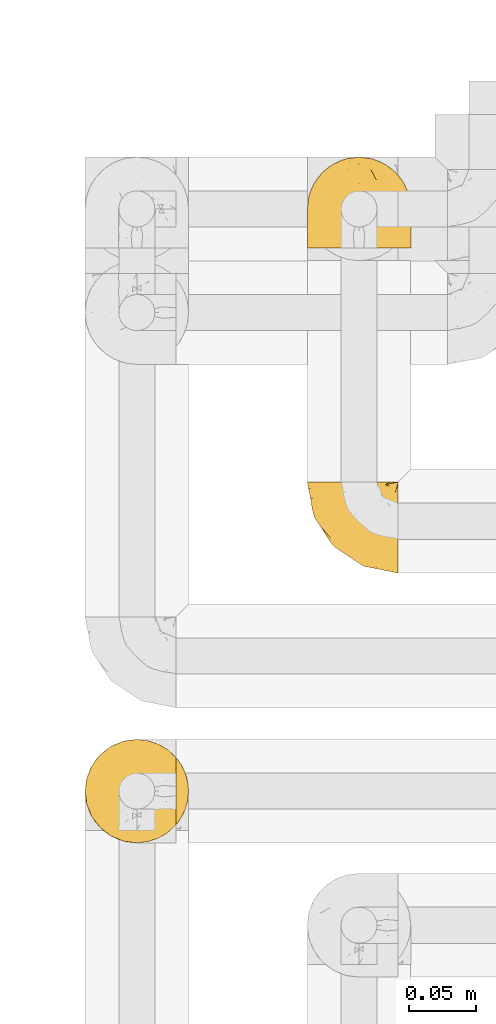
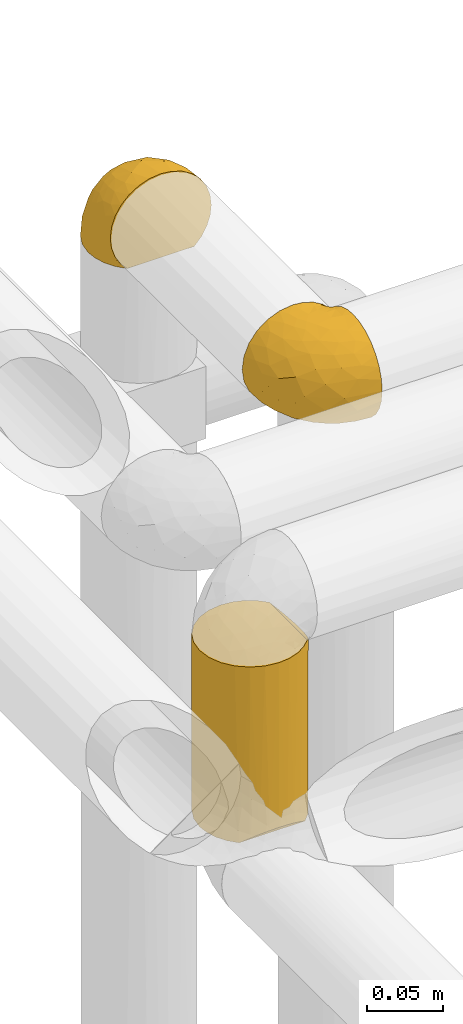
# One storey, part 294 of 827: 3 coverings.
"""IFC2X3 building model written with IfcOpenShell, lengths in millimetres."""

from ifc_helpers import new_model, entity, si_unit, converted_unit, derived_unit, direction, frame, origin, place, context, subcontext, project, spatial, faceted_brep, element, save


model = new_model("IFC2X3")

# Units and contexts
model_context = context("Model", 3, precision=0.01, world=origin(), true_north=direction((6.12303176911189e-17, 1.0)))
body_context = subcontext(model_context, "Body", "Model", "MODEL_VIEW")
ifc_project = project(units=[si_unit("LENGTHUNIT", "METRE", prefix="MILLI"), si_unit("AREAUNIT", "SQUARE_METRE"), si_unit("VOLUMEUNIT", "CUBIC_METRE"), converted_unit("PLANEANGLEUNIT", "DEGREE", entity("IfcRatioMeasure", 0.0174532925199433), si_unit("PLANEANGLEUNIT", "RADIAN"), dimensions=[0, 0, 0, 0, 0, 0, 0]), si_unit("MASSUNIT", "GRAM", prefix="KILO"), derived_unit("MASSDENSITYUNIT", [(si_unit("MASSUNIT", "GRAM", prefix="KILO"), 1), (si_unit("LENGTHUNIT", "METRE"), -3)]), derived_unit("MOMENTOFINERTIAUNIT", [(si_unit("LENGTHUNIT", "METRE"), 4)]), si_unit("TIMEUNIT", "SECOND"), si_unit("FREQUENCYUNIT", "HERTZ"), si_unit("THERMODYNAMICTEMPERATUREUNIT", "DEGREE_CELSIUS"), derived_unit("THERMALTRANSMITTANCEUNIT", [(si_unit("MASSUNIT", "GRAM", prefix="KILO"), 1), (si_unit("THERMODYNAMICTEMPERATUREUNIT", "KELVIN"), -1), (si_unit("TIMEUNIT", "SECOND"), -3)]), derived_unit("VOLUMETRICFLOWRATEUNIT", [(si_unit("LENGTHUNIT", "METRE"), 3), (si_unit("TIMEUNIT", "SECOND"), -1)]), derived_unit("MASSFLOWRATEUNIT", [(si_unit("MASSUNIT", "GRAM", prefix="KILO"), 1), (si_unit("TIMEUNIT", "SECOND"), -1)]), derived_unit("ROTATIONALFREQUENCYUNIT", [(si_unit("TIMEUNIT", "SECOND"), -1)]), si_unit("ELECTRICCURRENTUNIT", "AMPERE"), si_unit("ELECTRICVOLTAGEUNIT", "VOLT"), si_unit("POWERUNIT", "WATT"), si_unit("FORCEUNIT", "NEWTON", prefix="KILO"), si_unit("ILLUMINANCEUNIT", "LUX"), si_unit("LUMINOUSFLUXUNIT", "LUMEN"), si_unit("LUMINOUSINTENSITYUNIT", "CANDELA"), derived_unit("USERDEFINED", [(si_unit("MASSUNIT", "GRAM", prefix="KILO"), -1), (si_unit("LENGTHUNIT", "METRE"), -2), (si_unit("TIMEUNIT", "SECOND"), 3), (si_unit("LUMINOUSFLUXUNIT", "LUMEN"), 1)]), derived_unit("LINEARVELOCITYUNIT", [(si_unit("LENGTHUNIT", "METRE"), 1), (si_unit("TIMEUNIT", "SECOND"), -1)]), si_unit("PRESSUREUNIT", "PASCAL"), derived_unit("USERDEFINED", [(si_unit("LENGTHUNIT", "METRE"), -2), (si_unit("MASSUNIT", "GRAM", prefix="KILO"), 1), (si_unit("TIMEUNIT", "SECOND"), -2)]), derived_unit("LINEARFORCEUNIT", [(si_unit("MASSUNIT", "GRAM", prefix="KILO"), 1), (si_unit("LENGTHUNIT", "METRE"), 1), (si_unit("TIMEUNIT", "SECOND"), -2), (si_unit("LENGTHUNIT", "METRE"), -1)]), derived_unit("PLANARFORCEUNIT", [(si_unit("MASSUNIT", "GRAM", prefix="KILO"), 1), (si_unit("LENGTHUNIT", "METRE"), 1), (si_unit("TIMEUNIT", "SECOND"), -2), (si_unit("LENGTHUNIT", "METRE"), -2)])], contexts=[model_context])

# Site, building, storey
site_placement = place(None, origin())
site = spatial("IfcSite", under=ifc_project, at=site_placement, CompositionType="ELEMENT")
building_placement = place(site_placement, origin())
building = spatial("IfcBuilding", under=site, at=building_placement, CompositionType="ELEMENT")
storey_placement = place(building_placement, frame((0.0, 0.0, 28200.0)))
storey = spatial("IfcBuildingStorey", under=building, at=storey_placement, Name="08", CompositionType="ELEMENT", Elevation=28200.0)

# Coverings
covering_1_placement = place(storey_placement, frame((34952.84, 15549.99, 2959.95)))
element("IfcCovering", 1, at=covering_1_placement, inside=storey, Name=":ADSK_", ObjectType=":ADSK_", PredefinedType="INSULATION", context=body_context, shape_type="Brep", body=[
    faceted_brep([(69.15, 23.36, 74.68), (69.15, 16.07, 70.1), (69.15, 9.98, 64.01), (69.15, 5.4, 56.72), (69.15, 2.56, 48.6), (69.15, 1.6, 40.05), (69.15, 2.56, 31.49), (69.15, 5.41, 23.36), (69.15, 9.99, 16.07), (69.15, 16.08, 9.98), (69.15, 23.37, 5.4), (69.15, 31.49, 2.56), (69.15, 40.05, 1.6), (69.15, 48.15, 2.46), (69.15, 55.88, 5.01), (69.15, 62.9, 9.13), (69.15, 68.89, 14.62), (69.15, 68.89, 16.82), (69.15, 68.89, 18.56), (69.15, 68.89, 20.52), (69.15, 68.89, 22.49), (69.15, 68.89, 24.46), (69.15, 68.89, 26.42), (69.15, 68.89, 28.39), (69.15, 68.89, 30.36), (69.15, 68.89, 32.55), (69.15, 68.89, 34.75), (69.15, 68.89, 36.94), (69.15, 68.89, 39.13), (69.15, 68.89, 41.33), (69.15, 68.89, 43.52), (69.15, 68.89, 45.72), (69.15, 68.89, 47.91), (69.15, 68.89, 50.11), (69.15, 68.89, 52.3), (69.15, 68.89, 54.49), (69.15, 68.89, 56.69), (69.15, 68.89, 58.88), (69.15, 68.89, 61.08), (69.15, 68.89, 63.27), (69.15, 68.89, 65.47), (69.15, 62.89, 70.97), (69.15, 55.86, 75.09), (69.15, 48.13, 77.64), (69.15, 40.05, 78.5), (69.15, 31.49, 77.53), (68.89, 69.15, 14.62), (62.89, 69.15, 9.12), (55.87, 69.15, 5.0), (48.14, 69.15, 2.46), (40.05, 69.15, 1.6), (30.09, 69.15, 2.91), (20.82, 69.15, 6.75), (12.86, 69.15, 12.86), (6.75, 69.15, 20.82), (2.91, 69.15, 30.09), (1.6, 69.15, 40.05), (2.91, 69.15, 50.0), (6.75, 69.15, 59.27), (12.86, 69.15, 67.23), (20.82, 69.15, 73.34), (30.09, 69.15, 77.19), (40.05, 69.15, 78.5), (48.14, 69.15, 77.63), (55.87, 69.15, 75.09), (62.89, 69.15, 70.97), (68.89, 69.15, 65.47), (68.89, 69.15, 63.27), (68.89, 69.15, 62.29), (68.89, 69.15, 60.7), (68.89, 69.15, 59.11), (68.89, 69.15, 57.52), (68.89, 69.15, 55.93), (68.89, 69.15, 54.34), (68.89, 69.15, 52.76), (68.89, 69.15, 51.17), (68.89, 69.15, 49.58), (68.89, 69.15, 47.99), (68.89, 69.15, 46.4), (68.89, 69.15, 44.81), (68.89, 69.15, 43.22), (68.89, 69.15, 41.63), (68.89, 69.15, 40.05), (68.89, 69.15, 38.46), (68.89, 69.15, 36.87), (68.89, 69.15, 35.28), (68.89, 69.15, 33.69), (68.89, 69.15, 32.1), (68.89, 69.15, 30.51), (68.89, 69.15, 28.92), (68.89, 69.15, 27.33), (68.89, 69.15, 25.37), (68.89, 69.15, 23.4), (68.89, 69.15, 21.21), (68.89, 69.15, 19.01), (68.89, 69.15, 16.82), (68.97, 68.96, 42.32), (68.96, 68.97, 44.02), (68.97, 68.97, 47.13), (68.97, 68.97, 48.74), (68.98, 68.95, 23.57), (68.97, 68.96, 25.13), (68.96, 68.98, 61.34), (68.96, 68.97, 22.02), (68.96, 68.97, 29.72), (68.96, 68.98, 56.73), (68.96, 68.97, 55.14), (68.96, 68.97, 37.66), (69.0, 68.94, 64.12), (68.96, 68.98, 28.13), (68.96, 68.98, 26.62), (68.97, 68.96, 31.46), (68.96, 68.97, 16.16), (68.96, 68.98, 39.16), (68.96, 68.98, 50.37), (68.97, 68.97, 17.69), (68.97, 68.96, 19.17), (68.97, 68.97, 62.78), (68.96, 68.97, 58.35), (68.96, 68.98, 45.53), (68.97, 68.96, 59.91), (68.97, 68.97, 65.47), (69.02, 68.94, 65.47), (69.08, 68.92, 65.47), (68.97, 68.97, 14.62), (68.94, 69.02, 14.62), (68.92, 69.08, 14.62), (68.96, 68.98, 20.59), (68.96, 68.97, 32.99), (68.95, 68.98, 34.48), (68.96, 68.97, 51.91), (68.92, 69.08, 65.47), (68.94, 69.02, 65.47), (68.98, 68.96, 53.48), (69.08, 68.92, 14.62), (69.02, 68.94, 14.62), (68.96, 68.97, 40.77), (68.97, 68.96, 35.97), (61.33, 67.02, 7.84), (53.1, 63.33, 3.53), (63.33, 64.61, 8.32), (55.53, 51.4, 2.19), (63.33, 53.1, 3.53), (54.6, 43.94, 1.6), (41.99, 61.87, 1.6), (57.07, 61.54, 4.57), (57.95, 57.95, 3.96), (51.56, 56.12, 2.28), (41.58, 63.4, 1.6), (61.7, 65.41, 7.69), (65.0, 63.04, 8.32), (67.02, 61.33, 7.84), (61.87, 41.99, 1.6), (49.27, 49.27, 1.6), (43.94, 54.6, 1.6), (61.21, 56.6, 4.34), (63.4, 41.58, 1.6), (33.11, 13.72, 29.63), (52.82, 5.82, 27.34), (43.3, 6.74, 40.05), (33.73, 58.82, 2.39), (36.52, 51.58, 2.43), (24.87, 42.09, 9.07), (14.17, 46.12, 16.64), (18.43, 55.56, 9.54), (28.67, 52.38, 4.52), (26.0, 61.54, 4.52), (49.25, 23.76, 7.49), (59.72, 20.5, 7.49), (55.1, 14.64, 12.85), (44.72, 41.77, 2.35), (34.15, 16.28, 22.66), (5.25, 49.4, 32.9), (6.75, 52.34, 25.33), (55.54, 4.3, 40.05), (10.47, 58.67, 16.64), (25.49, 25.26, 19.99), (35.53, 20.17, 16.37), (48.22, 34.7, 3.26), (58.71, 28.67, 3.75), (57.42, 8.62, 19.58), (34.84, 33.37, 7.5), (36.87, 41.35, 4.04), (45.01, 17.15, 13.94), (44.4, 12.68, 19.58), (23.96, 21.47, 28.21), (11.2, 41.11, 24.75), (10.56, 37.53, 31.42), (16.81, 30.64, 26.2), (17.38, 26.66, 33.36), (21.38, 21.38, 40.05), (32.34, 14.06, 40.05), (4.3, 55.54, 40.05), (20.65, 35.17, 16.14), (29.66, 29.04, 12.85), (39.6, 24.34, 10.47), (42.55, 29.33, 6.49), (6.74, 43.3, 40.05), (14.06, 32.34, 40.05), (26.84, 57.75, 75.57), (5.28, 49.41, 47.37), (18.52, 27.85, 52.91), (33.13, 13.7, 50.46), (55.1, 14.63, 67.23), (57.43, 8.61, 60.5), (20.72, 48.85, 70.55), (11.46, 54.13, 63.45), (17.69, 37.84, 62.61), (49.26, 23.75, 72.6), (59.73, 20.49, 72.6), (58.71, 28.66, 76.34), (29.72, 20.83, 59.34), (35.35, 55.15, 77.76), (43.94, 54.6, 78.5), (41.99, 61.87, 78.5), (63.4, 41.58, 78.5), (4.93, 57.58, 53.16), (17.46, 59.91, 70.55), (10.94, 36.94, 48.88), (8.92, 45.72, 54.76), (52.83, 5.82, 52.74), (29.34, 37.91, 71.93), (30.26, 50.18, 75.79), (44.4, 12.67, 60.5), (39.06, 49.29, 77.86), (43.06, 42.64, 77.64), (54.6, 43.94, 78.5), (49.27, 49.27, 78.5), (42.69, 19.45, 67.23), (48.2, 34.7, 76.82), (61.87, 41.99, 78.5), (33.44, 62.29, 77.8), (29.67, 29.01, 67.23), (38.5, 31.47, 73.2), (23.35, 37.18, 67.66), (34.97, 43.45, 75.99), (53.1, 63.33, 76.57), (59.68, 67.23, 73.21), (62.19, 66.07, 71.93), (64.11, 65.22, 71.07), (57.97, 61.99, 75.09), (57.95, 57.95, 76.13), (63.33, 53.09, 76.57), (51.77, 56.84, 77.69), (67.02, 61.33, 72.26), (64.98, 63.06, 71.77), (55.53, 51.41, 77.9), (61.22, 56.61, 75.75)], [[[0, 1, 2, 3, 4, 5, 6, 7, 8, 9, 10, 11, 12, 13, 14, 15, 16, 17, 18, 19, 20, 21, 22, 23, 24, 25, 26, 27, 28, 29, 30, 31, 32, 33, 34, 35, 36, 37, 38, 39, 40, 41, 42, 43, 44, 45]], [[46, 47, 48, 49, 50, 51, 52, 53, 54, 55, 56, 57, 58, 59, 60, 61, 62, 63, 64, 65, 66, 67, 68, 69, 70, 71, 72, 73, 74, 75, 76, 77, 78, 79, 80, 81, 82, 83, 84, 85, 86, 87, 88, 89, 90, 91, 92, 93, 94, 95]], [[96, 97, 30]], [[98, 77, 99]], [[100, 101, 21]], [[69, 68, 102]], [[20, 19, 103]], [[24, 23, 104]], [[20, 103, 100]], [[72, 105, 106]], [[84, 83, 107]], [[89, 88, 104]], [[108, 67, 66]], [[109, 110, 90]], [[111, 25, 24]], [[112, 17, 16]], [[82, 113, 83]], [[109, 23, 22]], [[114, 76, 75]], [[105, 36, 106]], [[104, 111, 24]], [[18, 115, 116]], [[97, 96, 80]], [[67, 108, 117]], [[105, 71, 118]], [[31, 97, 119]], [[102, 120, 69]], [[108, 121, 122, 123, 40]], [[112, 95, 115]], [[17, 115, 18]], [[94, 116, 115]], [[117, 68, 67]], [[38, 117, 39]], [[112, 124, 125, 126, 46]], [[17, 112, 115]], [[70, 120, 118]], [[39, 117, 108]], [[120, 38, 37]], [[120, 37, 118]], [[120, 70, 69]], [[116, 94, 127]], [[128, 86, 129]], [[117, 38, 102]], [[74, 130, 75]], [[99, 33, 32]], [[115, 95, 94]], [[39, 108, 40]], [[108, 66, 131, 132, 121]], [[105, 72, 71]], [[118, 37, 36]], [[71, 70, 118]], [[35, 106, 36]], [[36, 105, 118]], [[35, 133, 106]], [[74, 73, 133]], [[106, 133, 73]], [[99, 114, 33]], [[133, 35, 34]], [[73, 72, 106]], [[95, 112, 46]], [[112, 16, 134, 135, 124]], [[130, 114, 75]], [[99, 76, 114]], [[114, 130, 33]], [[34, 33, 130]], [[78, 77, 98]], [[98, 119, 78]], [[130, 133, 34]], [[133, 130, 74]], [[79, 97, 80]], [[98, 99, 32]], [[98, 32, 31]], [[77, 76, 99]], [[97, 79, 119]], [[136, 96, 29]], [[30, 97, 31]], [[136, 29, 28]], [[81, 80, 96]], [[29, 96, 30]], [[31, 119, 98]], [[119, 79, 78]], [[96, 136, 81]], [[82, 81, 136]], [[113, 107, 83]], [[84, 107, 137]], [[107, 27, 137]], [[113, 28, 107]], [[27, 107, 28]], [[85, 84, 137]], [[137, 27, 26]], [[113, 136, 28]], [[136, 113, 82]], [[109, 89, 104]], [[86, 85, 129]], [[89, 109, 90]], [[111, 87, 128]], [[26, 129, 137]], [[88, 111, 104]], [[25, 111, 128]], [[22, 110, 109]], [[23, 109, 104]], [[110, 91, 90]], [[100, 92, 101]], [[110, 22, 101]], [[91, 110, 101]], [[116, 19, 18]], [[111, 88, 87]], [[127, 103, 19]], [[25, 128, 26]], [[86, 128, 87]], [[128, 129, 26]], [[137, 129, 85]], [[120, 102, 38]], [[117, 102, 68]], [[91, 101, 92]], [[21, 101, 22]], [[93, 92, 103]], [[100, 21, 20]], [[100, 103, 92]], [[127, 93, 103]], [[93, 127, 94]], [[116, 127, 19]], [[126, 138, 47]], [[48, 138, 139]], [[140, 125, 124]], [[141, 142, 143]], [[144, 49, 139]], [[145, 140, 146]], [[48, 139, 49]], [[139, 145, 147]], [[49, 144, 148, 50]], [[126, 125, 149]], [[14, 13, 142]], [[150, 146, 140]], [[149, 140, 145]], [[151, 150, 135]], [[151, 14, 142]], [[16, 15, 134]], [[13, 152, 142]], [[124, 150, 140]], [[141, 143, 153]], [[14, 151, 15]], [[15, 151, 134]], [[47, 46, 126]], [[139, 154, 144]], [[138, 48, 47]], [[125, 140, 149]], [[135, 134, 151]], [[146, 155, 141]], [[145, 146, 147]], [[149, 139, 138]], [[147, 153, 154]], [[147, 146, 141]], [[139, 147, 154]], [[139, 149, 145]], [[149, 138, 126]], [[147, 141, 153]], [[146, 150, 155]], [[151, 155, 150]], [[142, 141, 155]], [[13, 12, 156, 152]], [[152, 143, 142]], [[151, 142, 155]], [[150, 124, 135]], [[157, 158, 159]], [[160, 154, 161]], [[162, 163, 164]], [[165, 166, 160]], [[167, 168, 169]], [[153, 170, 161]], [[156, 12, 11]], [[158, 157, 171]], [[172, 55, 173]], [[158, 6, 174]], [[175, 54, 53]], [[52, 166, 164]], [[52, 164, 53]], [[54, 175, 173]], [[166, 52, 51]], [[176, 177, 171]], [[178, 143, 179]], [[156, 11, 179]], [[8, 7, 180]], [[169, 9, 8]], [[179, 143, 152, 156]], [[179, 11, 10]], [[168, 179, 10]], [[181, 162, 182]], [[179, 167, 178]], [[183, 184, 177]], [[183, 169, 184]], [[176, 171, 185]], [[172, 186, 187]], [[158, 7, 6]], [[159, 158, 174]], [[184, 180, 158]], [[54, 173, 55]], [[180, 169, 8]], [[188, 189, 187]], [[9, 168, 10]], [[186, 188, 187]], [[190, 157, 159, 191]], [[55, 172, 192]], [[176, 193, 194]], [[161, 170, 182]], [[162, 164, 165]], [[175, 164, 163]], [[51, 50, 148]], [[167, 195, 196]], [[178, 182, 170]], [[6, 5, 174]], [[158, 180, 7]], [[169, 180, 184]], [[169, 168, 9]], [[179, 168, 167]], [[182, 162, 165]], [[162, 194, 193]], [[161, 165, 160]], [[195, 181, 196]], [[192, 172, 197]], [[192, 56, 55]], [[189, 190, 198]], [[198, 197, 187]], [[172, 187, 197]], [[185, 189, 188]], [[198, 187, 189]], [[186, 172, 173]], [[173, 163, 186]], [[193, 186, 163]], [[176, 185, 188]], [[185, 157, 190]], [[188, 186, 193]], [[177, 176, 194]], [[188, 193, 176]], [[162, 193, 163]], [[195, 177, 194]], [[171, 177, 184]], [[181, 195, 194]], [[183, 167, 169]], [[162, 181, 194]], [[196, 182, 178]], [[158, 171, 184]], [[171, 157, 185]], [[177, 195, 183]], [[167, 183, 195]], [[182, 196, 181]], [[178, 170, 143]], [[178, 167, 196]], [[164, 175, 53]], [[173, 175, 163]], [[160, 51, 148]], [[164, 166, 165]], [[51, 160, 166]], [[160, 148, 144, 154]], [[153, 161, 154]], [[182, 165, 161]], [[190, 189, 185]], [[143, 170, 153]], [[60, 199, 61]], [[197, 200, 192]], [[201, 190, 202]], [[200, 57, 192]], [[203, 204, 2]], [[205, 206, 207]], [[208, 209, 210]], [[211, 207, 201]], [[212, 213, 214]], [[45, 215, 210]], [[216, 206, 58]], [[45, 44, 215]], [[59, 217, 60]], [[60, 217, 199]], [[0, 45, 210]], [[218, 201, 219]], [[202, 159, 220]], [[205, 221, 222]], [[223, 204, 203]], [[1, 203, 2]], [[57, 200, 216]], [[220, 3, 204]], [[220, 174, 4]], [[1, 0, 209]], [[212, 224, 213]], [[225, 226, 227]], [[228, 223, 203]], [[208, 210, 229]], [[210, 226, 229]], [[3, 220, 4]], [[58, 206, 59]], [[209, 203, 1]], [[202, 220, 223]], [[228, 203, 208]], [[202, 211, 201]], [[3, 2, 204]], [[202, 190, 191, 159]], [[210, 215, 230, 226]], [[199, 212, 231]], [[232, 233, 221]], [[233, 208, 229]], [[207, 206, 219]], [[217, 206, 205]], [[227, 224, 225]], [[233, 232, 228]], [[201, 207, 219]], [[234, 232, 221]], [[218, 219, 200]], [[202, 223, 211]], [[174, 220, 159]], [[174, 5, 4]], [[61, 231, 62]], [[220, 204, 223]], [[210, 209, 0]], [[203, 209, 208]], [[225, 233, 229]], [[224, 227, 213]], [[221, 233, 235]], [[57, 56, 192]], [[198, 218, 197]], [[200, 219, 216]], [[201, 198, 190]], [[197, 218, 200]], [[198, 201, 218]], [[206, 216, 219]], [[58, 57, 216]], [[231, 212, 214]], [[222, 212, 199]], [[228, 211, 223]], [[207, 211, 232]], [[62, 231, 214]], [[199, 231, 61]], [[233, 228, 208]], [[211, 228, 232]], [[222, 221, 235]], [[234, 205, 207]], [[206, 217, 59]], [[199, 217, 205]], [[205, 222, 199]], [[224, 222, 235]], [[222, 224, 212]], [[224, 235, 225]], [[233, 225, 235]], [[226, 225, 229]], [[205, 234, 221]], [[207, 232, 234]], [[63, 214, 236]], [[214, 213, 236]], [[214, 63, 62]], [[237, 236, 238]], [[238, 132, 131]], [[236, 237, 64]], [[239, 240, 241]], [[63, 236, 64]], [[131, 66, 65]], [[237, 131, 65]], [[242, 230, 43]], [[237, 65, 64]], [[239, 121, 132]], [[42, 242, 43]], [[241, 240, 243]], [[41, 123, 244]], [[43, 230, 215, 44]], [[244, 122, 245]], [[227, 246, 243]], [[241, 243, 246]], [[121, 239, 245]], [[41, 40, 123]], [[132, 238, 239]], [[244, 42, 41]], [[131, 237, 238]], [[240, 239, 238]], [[245, 239, 241]], [[247, 241, 246]], [[247, 244, 245]], [[238, 236, 240]], [[243, 236, 213]], [[236, 243, 240]], [[226, 246, 227]], [[243, 213, 227]], [[226, 242, 246]], [[241, 247, 245]], [[246, 242, 247]], [[244, 247, 242]], [[242, 226, 230]], [[42, 244, 242]], [[122, 244, 123]], [[122, 121, 245]]]),
])
covering_2_placement = place(storey_placement, frame((34952.84, 15791.35, 2969.3)))
element("IfcCovering", 2, at=covering_2_placement, inside=storey, Name=":ADSK_", ObjectType=":ADSK_", PredefinedType="INSULATION", context=body_context, shape_type="Brep", body=[
    faceted_brep([(74.68, 1.6, 47.38), (70.1, 1.6, 54.67), (64.01, 1.6, 60.76), (56.72, 1.6, 65.34), (48.6, 1.6, 68.18), (40.05, 1.6, 69.15), (31.49, 1.6, 68.18), (23.36, 1.6, 65.33), (16.07, 1.6, 60.75), (9.98, 1.6, 54.66), (5.4, 1.6, 47.37), (2.56, 1.6, 39.25), (1.6, 1.6, 30.7), (2.46, 1.6, 22.59), (5.01, 1.6, 14.86), (9.13, 1.6, 7.84), (14.62, 1.6, 1.85), (16.82, 1.6, 1.85), (18.56, 1.6, 1.85), (20.52, 1.6, 1.85), (22.49, 1.6, 1.85), (24.46, 1.6, 1.85), (26.42, 1.6, 1.85), (28.39, 1.6, 1.85), (30.36, 1.6, 1.85), (32.55, 1.6, 1.85), (34.75, 1.6, 1.85), (36.94, 1.6, 1.85), (39.13, 1.6, 1.85), (41.33, 1.6, 1.85), (43.52, 1.6, 1.85), (45.72, 1.6, 1.85), (47.91, 1.6, 1.85), (50.11, 1.6, 1.85), (52.3, 1.6, 1.85), (54.49, 1.6, 1.85), (56.69, 1.6, 1.85), (58.88, 1.6, 1.85), (61.08, 1.6, 1.85), (63.27, 1.6, 1.85), (65.47, 1.6, 1.85), (70.97, 1.6, 7.85), (75.09, 1.6, 14.88), (77.64, 1.6, 22.61), (78.5, 1.6, 30.7), (77.53, 1.6, 39.26), (14.62, 1.85, 1.6), (9.12, 7.85, 1.6), (5.0, 14.87, 1.6), (2.46, 22.6, 1.6), (1.6, 30.7, 1.6), (2.91, 40.65, 1.6), (6.75, 49.92, 1.6), (12.86, 57.88, 1.6), (20.82, 63.99, 1.6), (30.09, 67.84, 1.6), (40.05, 69.15, 1.6), (50.0, 67.84, 1.6), (59.27, 63.99, 1.6), (67.23, 57.88, 1.6), (73.34, 49.92, 1.6), (77.19, 40.65, 1.6), (78.5, 30.7, 1.6), (77.63, 22.6, 1.6), (75.09, 14.87, 1.6), (70.97, 7.85, 1.6), (65.47, 1.85, 1.6), (63.27, 1.85, 1.6), (62.29, 1.85, 1.6), (60.7, 1.85, 1.6), (59.11, 1.85, 1.6), (57.52, 1.85, 1.6), (55.93, 1.85, 1.6), (54.34, 1.85, 1.6), (52.76, 1.85, 1.6), (51.17, 1.85, 1.6), (49.58, 1.85, 1.6), (47.99, 1.85, 1.6), (46.4, 1.85, 1.6), (44.81, 1.85, 1.6), (43.22, 1.85, 1.6), (41.63, 1.85, 1.6), (40.05, 1.85, 1.6), (38.46, 1.85, 1.6), (36.87, 1.85, 1.6), (35.28, 1.85, 1.6), (33.69, 1.85, 1.6), (32.1, 1.85, 1.6), (30.51, 1.85, 1.6), (28.92, 1.85, 1.6), (27.33, 1.85, 1.6), (25.37, 1.85, 1.6), (23.4, 1.85, 1.6), (21.21, 1.85, 1.6), (19.01, 1.85, 1.6), (16.82, 1.85, 1.6), (42.32, 1.77, 1.78), (44.02, 1.78, 1.77), (47.13, 1.77, 1.78), (48.74, 1.77, 1.77), (23.57, 1.76, 1.79), (25.13, 1.77, 1.78), (61.34, 1.79, 1.76), (22.02, 1.78, 1.77), (29.72, 1.78, 1.77), (56.73, 1.78, 1.76), (55.14, 1.78, 1.77), (37.66, 1.78, 1.77), (64.12, 1.74, 1.8), (28.13, 1.78, 1.76), (26.62, 1.78, 1.77), (31.46, 1.77, 1.78), (16.16, 1.78, 1.77), (39.16, 1.78, 1.77), (50.37, 1.78, 1.76), (17.69, 1.77, 1.77), (19.17, 1.77, 1.78), (62.78, 1.77, 1.77), (58.35, 1.78, 1.77), (45.53, 1.78, 1.77), (59.91, 1.77, 1.78), (65.47, 1.77, 1.77), (65.47, 1.72, 1.8), (65.47, 1.66, 1.82), (14.62, 1.77, 1.77), (14.62, 1.8, 1.72), (14.62, 1.82, 1.66), (20.59, 1.79, 1.76), (32.99, 1.78, 1.77), (34.48, 1.79, 1.76), (51.91, 1.78, 1.77), (65.47, 1.82, 1.66), (65.47, 1.8, 1.72), (53.48, 1.76, 1.78), (14.62, 1.66, 1.82), (14.62, 1.72, 1.8), (40.77, 1.78, 1.77), (35.97, 1.77, 1.78), (7.84, 9.41, 3.72), (3.53, 17.65, 7.41), (8.32, 7.41, 6.13), (2.19, 15.21, 19.34), (3.53, 7.41, 17.64), (1.6, 16.15, 26.8), (1.6, 28.75, 8.87), (4.57, 13.67, 9.2), (3.96, 12.79, 12.79), (2.28, 19.18, 14.62), (1.6, 29.16, 7.34), (7.69, 9.04, 5.33), (8.32, 5.74, 7.7), (7.84, 3.72, 9.41), (1.6, 8.87, 28.75), (1.6, 21.47, 21.47), (1.6, 26.8, 16.15), (4.34, 9.53, 14.14), (1.6, 7.34, 29.16), (29.63, 37.63, 57.02), (27.34, 17.92, 64.92), (40.05, 27.45, 64.0), (2.39, 37.01, 11.92), (2.43, 34.22, 19.16), (9.07, 45.87, 28.65), (16.64, 56.57, 24.62), (9.54, 52.31, 15.19), (4.52, 42.07, 18.36), (4.52, 44.74, 9.2), (7.49, 21.49, 46.98), (7.49, 11.02, 50.24), (12.85, 15.64, 56.1), (2.35, 26.02, 28.97), (22.66, 36.59, 54.46), (32.9, 65.49, 21.34), (25.33, 63.99, 18.4), (40.05, 15.2, 66.44), (16.64, 60.27, 12.07), (19.99, 45.25, 45.49), (16.37, 35.21, 50.57), (3.26, 22.52, 36.04), (3.75, 12.03, 42.07), (19.58, 13.32, 62.12), (7.5, 35.9, 37.37), (4.04, 33.87, 29.39), (13.94, 25.73, 53.59), (19.58, 26.34, 58.06), (28.21, 46.78, 49.27), (24.75, 59.54, 29.63), (31.42, 60.18, 33.21), (26.2, 53.93, 40.1), (33.36, 53.36, 44.08), (40.05, 49.36, 49.36), (40.05, 38.4, 56.68), (40.05, 66.44, 15.2), (16.14, 50.09, 35.57), (12.85, 41.08, 41.7), (10.47, 31.14, 46.4), (6.49, 28.19, 41.41), (40.05, 64.0, 27.45), (40.05, 56.68, 38.4), (75.57, 43.9, 12.99), (47.37, 65.46, 21.33), (52.91, 52.22, 42.89), (50.46, 37.61, 57.04), (67.23, 15.64, 56.11), (60.5, 13.31, 62.13), (70.55, 50.02, 21.89), (63.45, 59.28, 16.62), (62.61, 53.05, 32.9), (72.6, 21.48, 46.99), (72.6, 11.01, 50.25), (76.34, 12.03, 42.08), (59.34, 41.02, 49.91), (77.76, 35.39, 15.6), (78.5, 26.8, 16.15), (78.5, 28.75, 8.87), (78.5, 7.34, 29.16), (53.16, 65.81, 13.16), (70.55, 53.28, 10.83), (48.88, 59.8, 33.8), (54.76, 61.82, 25.02), (52.74, 17.91, 64.92), (71.93, 41.4, 32.83), (75.79, 40.48, 20.56), (60.5, 26.34, 58.07), (77.86, 31.68, 21.46), (77.64, 27.68, 28.1), (78.5, 16.15, 26.8), (78.5, 21.47, 21.47), (67.23, 28.05, 51.29), (76.82, 22.54, 36.04), (78.5, 8.87, 28.75), (77.8, 37.3, 8.45), (67.23, 41.07, 41.73), (73.2, 32.24, 39.27), (67.66, 47.4, 33.56), (75.99, 35.77, 27.29), (76.57, 17.65, 7.41), (73.21, 11.06, 3.51), (71.93, 8.55, 4.68), (71.07, 6.63, 5.52), (75.09, 12.77, 8.75), (76.13, 12.79, 12.79), (76.57, 7.41, 17.65), (77.69, 18.97, 13.9), (72.26, 3.72, 9.42), (71.77, 5.76, 7.68), (77.9, 15.21, 19.33), (75.75, 9.52, 14.13)], [[[0, 1, 2, 3, 4, 5, 6, 7, 8, 9, 10, 11, 12, 13, 14, 15, 16, 17, 18, 19, 20, 21, 22, 23, 24, 25, 26, 27, 28, 29, 30, 31, 32, 33, 34, 35, 36, 37, 38, 39, 40, 41, 42, 43, 44, 45]], [[46, 47, 48, 49, 50, 51, 52, 53, 54, 55, 56, 57, 58, 59, 60, 61, 62, 63, 64, 65, 66, 67, 68, 69, 70, 71, 72, 73, 74, 75, 76, 77, 78, 79, 80, 81, 82, 83, 84, 85, 86, 87, 88, 89, 90, 91, 92, 93, 94, 95]], [[96, 97, 30]], [[98, 77, 99]], [[100, 101, 21]], [[69, 68, 102]], [[20, 19, 103]], [[24, 23, 104]], [[20, 103, 100]], [[72, 105, 106]], [[84, 83, 107]], [[89, 88, 104]], [[108, 67, 66]], [[109, 110, 90]], [[111, 25, 24]], [[112, 17, 16]], [[82, 113, 83]], [[109, 23, 22]], [[114, 76, 75]], [[105, 36, 106]], [[104, 111, 24]], [[18, 115, 116]], [[97, 96, 80]], [[67, 108, 117]], [[105, 71, 118]], [[31, 97, 119]], [[102, 120, 69]], [[108, 121, 122, 123, 40]], [[112, 95, 115]], [[17, 115, 18]], [[94, 116, 115]], [[117, 68, 67]], [[38, 117, 39]], [[112, 124, 125, 126, 46]], [[17, 112, 115]], [[70, 120, 118]], [[39, 117, 108]], [[120, 38, 37]], [[120, 37, 118]], [[120, 70, 69]], [[116, 94, 127]], [[128, 86, 129]], [[117, 38, 102]], [[74, 130, 75]], [[99, 33, 32]], [[115, 95, 94]], [[39, 108, 40]], [[108, 66, 131, 132, 121]], [[105, 72, 71]], [[118, 37, 36]], [[71, 70, 118]], [[35, 106, 36]], [[36, 105, 118]], [[35, 133, 106]], [[74, 73, 133]], [[106, 133, 73]], [[99, 114, 33]], [[133, 35, 34]], [[73, 72, 106]], [[95, 112, 46]], [[112, 16, 134, 135, 124]], [[130, 114, 75]], [[99, 76, 114]], [[114, 130, 33]], [[34, 33, 130]], [[78, 77, 98]], [[98, 119, 78]], [[130, 133, 34]], [[133, 130, 74]], [[79, 97, 80]], [[98, 99, 32]], [[98, 32, 31]], [[77, 76, 99]], [[97, 79, 119]], [[136, 96, 29]], [[30, 97, 31]], [[136, 29, 28]], [[81, 80, 96]], [[29, 96, 30]], [[31, 119, 98]], [[119, 79, 78]], [[96, 136, 81]], [[82, 81, 136]], [[113, 107, 83]], [[84, 107, 137]], [[107, 27, 137]], [[113, 28, 107]], [[27, 107, 28]], [[85, 84, 137]], [[137, 27, 26]], [[113, 136, 28]], [[136, 113, 82]], [[109, 89, 104]], [[86, 85, 129]], [[89, 109, 90]], [[111, 87, 128]], [[26, 129, 137]], [[88, 111, 104]], [[25, 111, 128]], [[22, 110, 109]], [[23, 109, 104]], [[110, 91, 90]], [[100, 92, 101]], [[110, 22, 101]], [[91, 110, 101]], [[116, 19, 18]], [[111, 88, 87]], [[127, 103, 19]], [[25, 128, 26]], [[86, 128, 87]], [[128, 129, 26]], [[137, 129, 85]], [[120, 102, 38]], [[117, 102, 68]], [[91, 101, 92]], [[21, 101, 22]], [[93, 92, 103]], [[100, 21, 20]], [[100, 103, 92]], [[127, 93, 103]], [[93, 127, 94]], [[116, 127, 19]], [[126, 138, 47]], [[48, 138, 139]], [[140, 125, 124]], [[141, 142, 143]], [[144, 49, 139]], [[145, 140, 146]], [[48, 139, 49]], [[139, 145, 147]], [[49, 144, 148, 50]], [[126, 125, 149]], [[14, 13, 142]], [[150, 146, 140]], [[149, 140, 145]], [[151, 150, 135]], [[151, 14, 142]], [[16, 15, 134]], [[13, 152, 142]], [[124, 150, 140]], [[141, 143, 153]], [[14, 151, 15]], [[15, 151, 134]], [[47, 46, 126]], [[139, 154, 144]], [[138, 48, 47]], [[125, 140, 149]], [[135, 134, 151]], [[146, 155, 141]], [[145, 146, 147]], [[149, 139, 138]], [[147, 153, 154]], [[147, 146, 141]], [[139, 147, 154]], [[139, 149, 145]], [[149, 138, 126]], [[147, 141, 153]], [[146, 150, 155]], [[151, 155, 150]], [[142, 141, 155]], [[13, 12, 156, 152]], [[152, 143, 142]], [[151, 142, 155]], [[150, 124, 135]], [[157, 158, 159]], [[160, 154, 161]], [[162, 163, 164]], [[165, 166, 160]], [[167, 168, 169]], [[153, 170, 161]], [[156, 12, 11]], [[158, 157, 171]], [[172, 55, 173]], [[158, 6, 174]], [[175, 54, 53]], [[52, 166, 164]], [[52, 164, 53]], [[54, 175, 173]], [[166, 52, 51]], [[176, 177, 171]], [[178, 143, 179]], [[156, 11, 179]], [[8, 7, 180]], [[169, 9, 8]], [[179, 143, 152, 156]], [[179, 11, 10]], [[168, 179, 10]], [[181, 162, 182]], [[179, 167, 178]], [[183, 184, 177]], [[183, 169, 184]], [[176, 171, 185]], [[172, 186, 187]], [[158, 7, 6]], [[159, 158, 174]], [[184, 180, 158]], [[54, 173, 55]], [[180, 169, 8]], [[188, 189, 187]], [[9, 168, 10]], [[186, 188, 187]], [[190, 157, 159, 191]], [[55, 172, 192]], [[176, 193, 194]], [[161, 170, 182]], [[162, 164, 165]], [[175, 164, 163]], [[51, 50, 148]], [[167, 195, 196]], [[178, 182, 170]], [[6, 5, 174]], [[158, 180, 7]], [[169, 180, 184]], [[169, 168, 9]], [[179, 168, 167]], [[182, 162, 165]], [[162, 194, 193]], [[161, 165, 160]], [[195, 181, 196]], [[192, 172, 197]], [[192, 56, 55]], [[189, 190, 198]], [[198, 197, 187]], [[172, 187, 197]], [[185, 189, 188]], [[198, 187, 189]], [[186, 172, 173]], [[173, 163, 186]], [[193, 186, 163]], [[176, 185, 188]], [[185, 157, 190]], [[188, 186, 193]], [[177, 176, 194]], [[188, 193, 176]], [[162, 193, 163]], [[195, 177, 194]], [[171, 177, 184]], [[181, 195, 194]], [[183, 167, 169]], [[162, 181, 194]], [[196, 182, 178]], [[158, 171, 184]], [[171, 157, 185]], [[177, 195, 183]], [[167, 183, 195]], [[182, 196, 181]], [[178, 170, 143]], [[178, 167, 196]], [[164, 175, 53]], [[173, 175, 163]], [[160, 51, 148]], [[164, 166, 165]], [[51, 160, 166]], [[160, 148, 144, 154]], [[153, 161, 154]], [[182, 165, 161]], [[190, 189, 185]], [[143, 170, 153]], [[60, 199, 61]], [[197, 200, 192]], [[201, 190, 202]], [[200, 57, 192]], [[203, 204, 2]], [[205, 206, 207]], [[208, 209, 210]], [[211, 207, 201]], [[212, 213, 214]], [[45, 215, 210]], [[216, 206, 58]], [[45, 44, 215]], [[59, 217, 60]], [[60, 217, 199]], [[0, 45, 210]], [[218, 201, 219]], [[202, 159, 220]], [[205, 221, 222]], [[223, 204, 203]], [[1, 203, 2]], [[57, 200, 216]], [[220, 3, 204]], [[220, 174, 4]], [[1, 0, 209]], [[212, 224, 213]], [[225, 226, 227]], [[228, 223, 203]], [[208, 210, 229]], [[210, 226, 229]], [[3, 220, 4]], [[58, 206, 59]], [[209, 203, 1]], [[202, 220, 223]], [[228, 203, 208]], [[202, 211, 201]], [[3, 2, 204]], [[202, 190, 191, 159]], [[210, 215, 230, 226]], [[199, 212, 231]], [[232, 233, 221]], [[233, 208, 229]], [[207, 206, 219]], [[217, 206, 205]], [[227, 224, 225]], [[233, 232, 228]], [[201, 207, 219]], [[234, 232, 221]], [[218, 219, 200]], [[202, 223, 211]], [[174, 220, 159]], [[174, 5, 4]], [[61, 231, 62]], [[220, 204, 223]], [[210, 209, 0]], [[203, 209, 208]], [[225, 233, 229]], [[224, 227, 213]], [[221, 233, 235]], [[57, 56, 192]], [[198, 218, 197]], [[200, 219, 216]], [[201, 198, 190]], [[197, 218, 200]], [[198, 201, 218]], [[206, 216, 219]], [[58, 57, 216]], [[231, 212, 214]], [[222, 212, 199]], [[228, 211, 223]], [[207, 211, 232]], [[62, 231, 214]], [[199, 231, 61]], [[233, 228, 208]], [[211, 228, 232]], [[222, 221, 235]], [[234, 205, 207]], [[206, 217, 59]], [[199, 217, 205]], [[205, 222, 199]], [[224, 222, 235]], [[222, 224, 212]], [[224, 235, 225]], [[233, 225, 235]], [[226, 225, 229]], [[205, 234, 221]], [[207, 232, 234]], [[63, 214, 236]], [[214, 213, 236]], [[214, 63, 62]], [[237, 236, 238]], [[238, 132, 131]], [[236, 237, 64]], [[239, 240, 241]], [[63, 236, 64]], [[131, 66, 65]], [[237, 131, 65]], [[242, 230, 43]], [[237, 65, 64]], [[239, 121, 132]], [[42, 242, 43]], [[241, 240, 243]], [[41, 123, 244]], [[43, 230, 215, 44]], [[244, 122, 245]], [[227, 246, 243]], [[241, 243, 246]], [[121, 239, 245]], [[41, 40, 123]], [[132, 238, 239]], [[244, 42, 41]], [[131, 237, 238]], [[240, 239, 238]], [[245, 239, 241]], [[247, 241, 246]], [[247, 244, 245]], [[238, 236, 240]], [[243, 236, 213]], [[236, 243, 240]], [[226, 246, 227]], [[243, 213, 227]], [[226, 242, 246]], [[241, 247, 245]], [[246, 242, 247]], [[244, 247, 242]], [[242, 226, 230]], [[42, 244, 242]], [[122, 244, 123]], [[122, 121, 245]]]),
])
covering_3_placement = place(storey_placement, frame((34787.85, 15349.6, 2827.5)))
element("IfcCovering", 3, at=covering_3_placement, inside=storey, Name=":ADSK_", ObjectType=":ADSK_", PredefinedType="INSULATION", context=body_context, shape_type="Brep", body=[
    faceted_brep([(2.48, 31.79, 1.6), (1.6, 40.0, 1.6), (2.9, 49.93, 1.6), (6.74, 59.2, 1.6), (12.84, 67.15, 1.6), (20.8, 73.25, 1.6), (30.06, 77.09, 1.6), (40.0, 78.4, 1.6), (49.93, 77.09, 1.6), (59.2, 73.25, 1.6), (67.15, 67.15, 1.6), (73.25, 59.2, 1.6), (77.09, 49.93, 1.6), (78.4, 40.0, 1.6), (77.51, 31.79, 1.6), (74.9, 23.98, 1.6), (70.68, 16.91, 1.6), (65.05, 10.9, 1.6), (14.94, 10.9, 1.6), (9.31, 16.91, 1.6), (5.09, 23.98, 1.6), (1.6, 40.0, 143.4), (2.9, 30.06, 143.4), (6.74, 20.8, 143.4), (12.84, 12.84, 143.4), (20.8, 6.74, 143.4), (30.06, 2.9, 143.4), (40.0, 1.6, 143.4), (48.2, 2.48, 143.4), (56.01, 5.09, 143.4), (63.08, 9.31, 143.4), (69.1, 14.94, 143.4), (69.1, 65.05, 143.4), (63.08, 70.68, 143.4), (56.01, 74.9, 143.4), (48.2, 77.51, 143.4), (40.0, 78.4, 143.4), (30.06, 77.09, 143.4), (20.8, 73.25, 143.4), (12.84, 67.15, 143.4), (6.74, 59.2, 143.4), (2.9, 49.93, 143.4), (73.07, 59.51, 139.42), (76.0, 53.36, 136.5), (77.79, 46.78, 134.7), (78.4, 40.0, 134.1), (77.79, 33.21, 134.7), (76.0, 26.63, 136.5), (73.07, 20.48, 139.42), (59.51, 6.92, 5.57), (53.36, 4.0, 8.5), (46.78, 2.2, 10.29), (40.0, 1.6, 10.9), (33.21, 2.2, 10.29), (26.63, 4.0, 8.5), (20.48, 6.92, 5.57)], [[[0, 1, 2, 3, 4, 5, 6, 7, 8, 9, 10, 11, 12, 13, 14, 15, 16, 17, 18, 19, 20]], [[21, 22, 23, 24, 25, 26, 27, 28, 29, 30, 31, 32, 33, 34, 35, 36, 37, 38, 39, 40, 41]], [[36, 35, 7]], [[34, 33, 9]], [[35, 34, 8]], [[8, 7, 35]], [[9, 8, 34]], [[33, 10, 9]], [[33, 32, 10]], [[32, 42, 11]], [[43, 44, 12]], [[42, 43, 11]], [[11, 43, 12]], [[13, 12, 44]], [[45, 13, 44]], [[32, 11, 10]], [[46, 47, 14]], [[48, 31, 16]], [[47, 48, 15]], [[45, 46, 13]], [[14, 13, 46]], [[47, 15, 14]], [[48, 16, 15]], [[31, 17, 16]], [[49, 30, 29]], [[50, 29, 28]], [[51, 28, 27]], [[49, 17, 30]], [[51, 50, 28]], [[52, 51, 27]], [[49, 29, 50]], [[30, 17, 31]], [[53, 52, 27]], [[53, 27, 26]], [[54, 26, 25]], [[54, 53, 26]], [[18, 55, 25]], [[54, 25, 55]], [[25, 24, 18]], [[19, 24, 23]], [[20, 23, 22]], [[0, 22, 21]], [[19, 23, 20]], [[20, 22, 0]], [[21, 1, 0]], [[24, 19, 18]], [[2, 1, 21, 41]], [[3, 2, 41, 40]], [[40, 39, 4, 3]], [[6, 5, 38, 37]], [[7, 6, 37, 36]], [[39, 38, 5, 4]], [[49, 50, 51, 52, 53, 54, 55, 18, 17]], [[31, 48, 47, 46, 45, 44, 43, 42, 32]]]),
])

save(model, "model.ifc")
